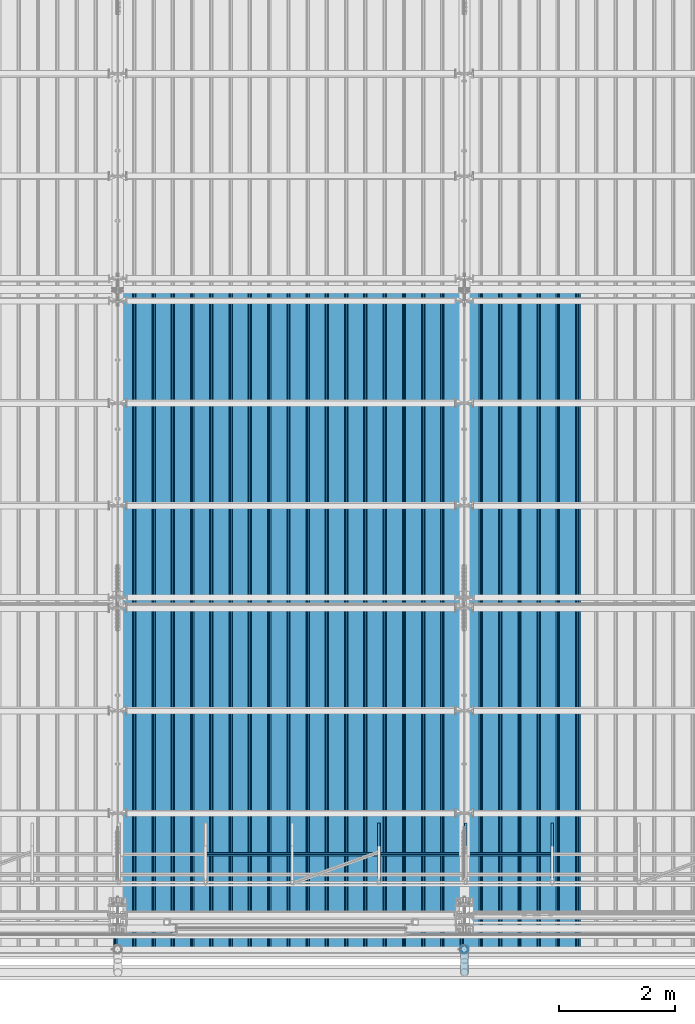
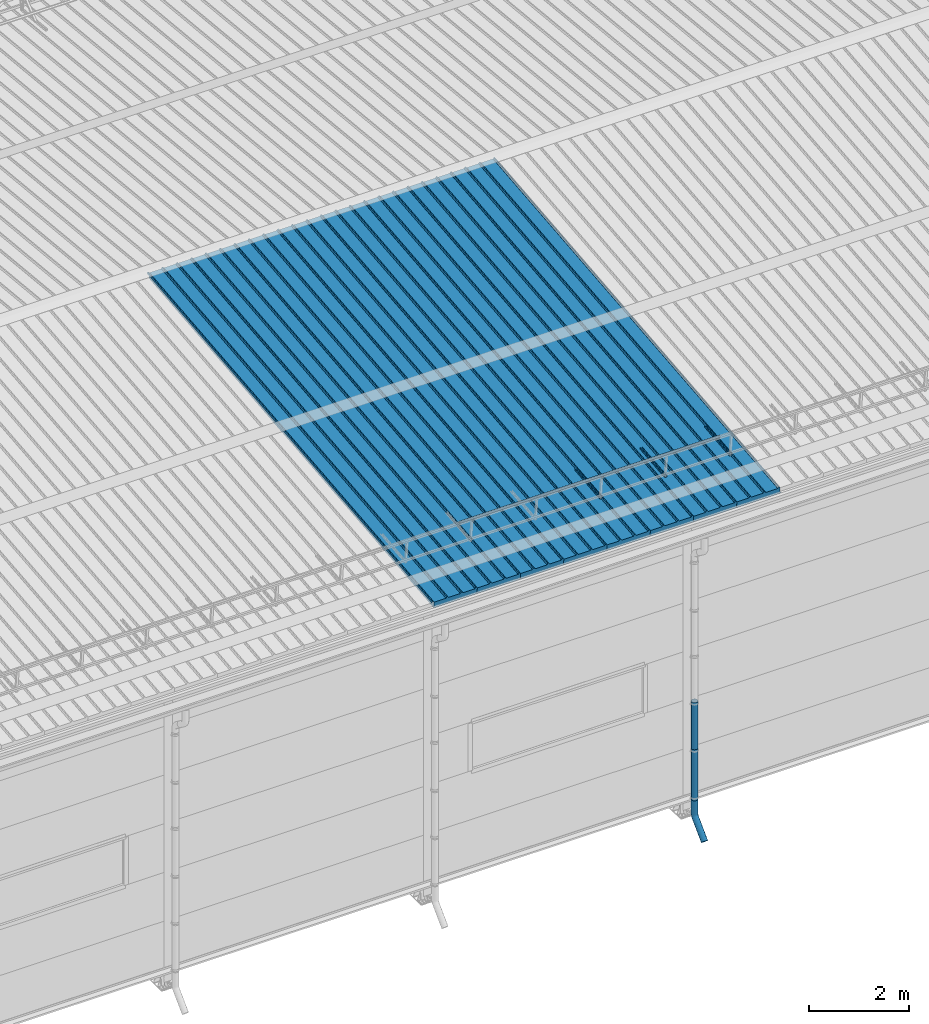
# One storey, part 43 of 709: 15 beams, 15 elements without a shape of their own.
"""IFC4 building model written with IfcOpenShell, lengths in millimetres."""

from ifc_helpers import new_model, entity, si_unit, direction, frame, origin_with_axes, place, context, subcontext, project, spatial, line, indexed_curve, outline, extrude, material, element, aggregate, save


model = new_model("IFC4")

# Units and contexts
model_context = context("Model", 3, precision=0.2, world=origin_with_axes(), true_north=direction((0.0, 1.0)))
body_context = subcontext(model_context, "Body", "Model", "MODEL_VIEW")
ifc_project = project(units=[si_unit("LENGTHUNIT", "METRE", prefix="MILLI"), si_unit("AREAUNIT", "SQUARE_METRE"), si_unit("VOLUMEUNIT", "CUBIC_METRE"), si_unit("MASSUNIT", "GRAM", prefix="KILO"), si_unit("TIMEUNIT", "SECOND"), si_unit("PLANEANGLEUNIT", "RADIAN"), si_unit("SOLIDANGLEUNIT", "STERADIAN"), si_unit("THERMODYNAMICTEMPERATUREUNIT", "DEGREE_CELSIUS"), si_unit("LUMINOUSINTENSITYUNIT", "LUMEN")], contexts=[model_context])

# Site, building, storey
site_placement = place(None, origin_with_axes())
site = spatial("IfcSite", under=ifc_project, at=site_placement, CompositionType="ELEMENT")
building_placement = place(site_placement, origin_with_axes())
building = spatial("IfcBuilding", under=site, at=building_placement, Name="Undefined", CompositionType="ELEMENT")
storey_placement = place(building_placement, origin_with_axes())
storey = spatial("IfcBuildingStorey", under=building, at=storey_placement, Name="Undefined", CompositionType="ELEMENT", Elevation=0.0)

# Assembly, beam
assembly_1_placement = place(storey_placement, frame((23452.44, -410.89541, 7279.78979), z_axis=(1.0, 0.0, 0.0), x_axis=(0.0, 0.9950371902, 0.099503719)))
assembly_1 = element("IfcElementAssembly", 1, at=assembly_1_placement, inside=storey)
ifc_material_1 = material(Name="Insulation", Category="Insulation")
beam_1_placement = place(assembly_1_placement, origin_with_axes())
beam_1 = element("IfcBeam", 2, at=beam_1_placement, material=ifc_material_1, ObjectType="P-99", context=body_context, shape_type="SolidModel", body=[
    extrude(outline(indexed_curve([(-509.8453, 89.5), (-490.1547, 89.5), (-471.67949, 57.5), (-471.67949, -88.5), (-436.67949, -88.5), (-436.67949, -91.5), (562.55841, -91.5), (562.55841, -89.5), (527.55841, -89.5), (527.55841, 57.5), (510.2379, 88.5), (489.7621, 88.5), (472.44159, 58.5), (196.71923, 58.5), (177.66667, 91.5), (155.66667, 91.5), (136.61411, 58.5), (-136.61411, 58.5), (-155.66667, 91.5), (-177.66667, 91.5), (-196.71923, 58.5), (-469.94744, 58.5), (-489.0, 91.5), (-511.0, 91.5), (-527.16581, 63.5), (-525.43376, 62.5)], segments=[line(1, 2, 3, 4, 5, 6, 7, 8, 9, 10, 11, 12, 13, 14, 15, 16, 17, 18, 19, 20, 21, 22, 23, 24, 25, 26, 1)])), frame((0.0, 0.0, 0.0), z_axis=(-1.0, 0.0, 0.0), x_axis=(0.0, 0.0, 1.0)), (0.0, 0.0, -1.0), 11459.0),
])
aggregate(assembly_1, [beam_1])

assembly_2_placement = place(storey_placement, frame((22452.44, -410.89541, 7279.78979), z_axis=(1.0, 0.0, 0.0), x_axis=(0.0, 0.9950371902, 0.099503719)))
assembly_2 = element("IfcElementAssembly", 3, at=assembly_2_placement, inside=storey)
beam_2_placement = place(assembly_2_placement, origin_with_axes())
beam_2 = element("IfcBeam", 4, at=beam_2_placement, material=ifc_material_1, ObjectType="P-99", context=body_context, shape_type="SolidModel", body=[
    extrude(outline(indexed_curve([(-509.8453, 89.5), (-490.1547, 89.5), (-471.67949, 57.5), (-471.67949, -88.5), (-436.67949, -88.5), (-436.67949, -91.5), (562.55841, -91.5), (562.55841, -89.5), (527.55841, -89.5), (527.55841, 57.5), (510.2379, 88.5), (489.7621, 88.5), (472.44159, 58.5), (196.71923, 58.5), (177.66667, 91.5), (155.66667, 91.5), (136.61411, 58.5), (-136.61411, 58.5), (-155.66667, 91.5), (-177.66667, 91.5), (-196.71923, 58.5), (-469.94744, 58.5), (-489.0, 91.5), (-511.0, 91.5), (-527.16581, 63.5), (-525.43376, 62.5)], segments=[line(1, 2, 3, 4, 5, 6, 7, 8, 9, 10, 11, 12, 13, 14, 15, 16, 17, 18, 19, 20, 21, 22, 23, 24, 25, 26, 1)])), frame((0.0, 0.0, 0.0), z_axis=(-1.0, 0.0, 0.0), x_axis=(0.0, 0.0, 1.0)), (0.0, 0.0, -1.0), 11459.0),
])
aggregate(assembly_2, [beam_2])

assembly_3_placement = place(storey_placement, frame((21452.44, -410.89541, 7279.78979), z_axis=(1.0, 0.0, 0.0), x_axis=(0.0, 0.9950371902, 0.099503719)))
assembly_3 = element("IfcElementAssembly", 5, at=assembly_3_placement, inside=storey)
beam_3_placement = place(assembly_3_placement, origin_with_axes())
beam_3 = element("IfcBeam", 6, at=beam_3_placement, material=ifc_material_1, ObjectType="P-99", context=body_context, shape_type="SolidModel", body=[
    extrude(outline(indexed_curve([(-509.8453, 89.5), (-490.1547, 89.5), (-471.67949, 57.5), (-471.67949, -88.5), (-436.67949, -88.5), (-436.67949, -91.5), (562.55841, -91.5), (562.55841, -89.5), (527.55841, -89.5), (527.55841, 57.5), (510.2379, 88.5), (489.7621, 88.5), (472.44159, 58.5), (196.71923, 58.5), (177.66667, 91.5), (155.66667, 91.5), (136.61411, 58.5), (-136.61411, 58.5), (-155.66667, 91.5), (-177.66667, 91.5), (-196.71923, 58.5), (-469.94744, 58.5), (-489.0, 91.5), (-511.0, 91.5), (-527.16581, 63.5), (-525.43376, 62.5)], segments=[line(1, 2, 3, 4, 5, 6, 7, 8, 9, 10, 11, 12, 13, 14, 15, 16, 17, 18, 19, 20, 21, 22, 23, 24, 25, 26, 1)])), frame((0.0, 0.0, 0.0), z_axis=(-1.0, 0.0, 0.0), x_axis=(0.0, 0.0, 1.0)), (0.0, 0.0, -1.0), 11459.0),
])
aggregate(assembly_3, [beam_3])

assembly_4_placement = place(storey_placement, frame((20452.44, -410.89541, 7279.78979), z_axis=(1.0, 0.0, 0.0), x_axis=(0.0, 0.9950371902, 0.099503719)))
assembly_4 = element("IfcElementAssembly", 7, at=assembly_4_placement, inside=storey)
beam_4_placement = place(assembly_4_placement, origin_with_axes())
beam_4 = element("IfcBeam", 8, at=beam_4_placement, material=ifc_material_1, ObjectType="P-99", context=body_context, shape_type="SolidModel", body=[
    extrude(outline(indexed_curve([(-509.8453, 89.5), (-490.1547, 89.5), (-471.67949, 57.5), (-471.67949, -88.5), (-436.67949, -88.5), (-436.67949, -91.5), (562.55841, -91.5), (562.55841, -89.5), (527.55841, -89.5), (527.55841, 57.5), (510.2379, 88.5), (489.7621, 88.5), (472.44159, 58.5), (196.71923, 58.5), (177.66667, 91.5), (155.66667, 91.5), (136.61411, 58.5), (-136.61411, 58.5), (-155.66667, 91.5), (-177.66667, 91.5), (-196.71923, 58.5), (-469.94744, 58.5), (-489.0, 91.5), (-511.0, 91.5), (-527.16581, 63.5), (-525.43376, 62.5)], segments=[line(1, 2, 3, 4, 5, 6, 7, 8, 9, 10, 11, 12, 13, 14, 15, 16, 17, 18, 19, 20, 21, 22, 23, 24, 25, 26, 1)])), frame((0.0, 0.0, 0.0), z_axis=(-1.0, 0.0, 0.0), x_axis=(0.0, 0.0, 1.0)), (0.0, 0.0, -1.0), 11459.0),
])
aggregate(assembly_4, [beam_4])

assembly_5_placement = place(storey_placement, frame((19452.44, -410.89541, 7279.78979), z_axis=(1.0, 0.0, 0.0), x_axis=(0.0, 0.9950371902, 0.099503719)))
assembly_5 = element("IfcElementAssembly", 9, at=assembly_5_placement, inside=storey)
beam_5_placement = place(assembly_5_placement, origin_with_axes())
beam_5 = element("IfcBeam", 10, at=beam_5_placement, material=ifc_material_1, ObjectType="P-99", context=body_context, shape_type="SolidModel", body=[
    extrude(outline(indexed_curve([(-509.8453, 89.5), (-490.1547, 89.5), (-471.67949, 57.5), (-471.67949, -88.5), (-436.67949, -88.5), (-436.67949, -91.5), (562.55841, -91.5), (562.55841, -89.5), (527.55841, -89.5), (527.55841, 57.5), (510.2379, 88.5), (489.7621, 88.5), (472.44159, 58.5), (196.71923, 58.5), (177.66667, 91.5), (155.66667, 91.5), (136.61411, 58.5), (-136.61411, 58.5), (-155.66667, 91.5), (-177.66667, 91.5), (-196.71923, 58.5), (-469.94744, 58.5), (-489.0, 91.5), (-511.0, 91.5), (-527.16581, 63.5), (-525.43376, 62.5)], segments=[line(1, 2, 3, 4, 5, 6, 7, 8, 9, 10, 11, 12, 13, 14, 15, 16, 17, 18, 19, 20, 21, 22, 23, 24, 25, 26, 1)])), frame((0.0, 0.0, 0.0), z_axis=(-1.0, 0.0, 0.0), x_axis=(0.0, 0.0, 1.0)), (0.0, 0.0, -1.0), 11459.0),
])
aggregate(assembly_5, [beam_5])

assembly_6_placement = place(storey_placement, frame((18452.44, -410.89541, 7279.78979), z_axis=(1.0, 0.0, 0.0), x_axis=(0.0, 0.9950371902, 0.099503719)))
assembly_6 = element("IfcElementAssembly", 11, at=assembly_6_placement, inside=storey)
beam_6_placement = place(assembly_6_placement, origin_with_axes())
beam_6 = element("IfcBeam", 12, at=beam_6_placement, material=ifc_material_1, ObjectType="P-99", context=body_context, shape_type="SolidModel", body=[
    extrude(outline(indexed_curve([(-509.8453, 89.5), (-490.1547, 89.5), (-471.67949, 57.5), (-471.67949, -88.5), (-436.67949, -88.5), (-436.67949, -91.5), (562.55841, -91.5), (562.55841, -89.5), (527.55841, -89.5), (527.55841, 57.5), (510.2379, 88.5), (489.7621, 88.5), (472.44159, 58.5), (196.71923, 58.5), (177.66667, 91.5), (155.66667, 91.5), (136.61411, 58.5), (-136.61411, 58.5), (-155.66667, 91.5), (-177.66667, 91.5), (-196.71923, 58.5), (-469.94744, 58.5), (-489.0, 91.5), (-511.0, 91.5), (-527.16581, 63.5), (-525.43376, 62.5)], segments=[line(1, 2, 3, 4, 5, 6, 7, 8, 9, 10, 11, 12, 13, 14, 15, 16, 17, 18, 19, 20, 21, 22, 23, 24, 25, 26, 1)])), frame((0.0, 0.0, 0.0), z_axis=(-1.0, 0.0, 0.0), x_axis=(0.0, 0.0, 1.0)), (0.0, 0.0, -1.0), 11459.0),
])
aggregate(assembly_6, [beam_6])

assembly_7_placement = place(storey_placement, frame((17452.44, -410.89541, 7279.78979), z_axis=(1.0, 0.0, 0.0), x_axis=(0.0, 0.9950371902, 0.099503719)))
assembly_7 = element("IfcElementAssembly", 13, at=assembly_7_placement, inside=storey)
beam_7_placement = place(assembly_7_placement, origin_with_axes())
beam_7 = element("IfcBeam", 14, at=beam_7_placement, material=ifc_material_1, ObjectType="P-99", context=body_context, shape_type="SolidModel", body=[
    extrude(outline(indexed_curve([(-509.8453, 89.5), (-490.1547, 89.5), (-471.67949, 57.5), (-471.67949, -88.5), (-436.67949, -88.5), (-436.67949, -91.5), (562.55841, -91.5), (562.55841, -89.5), (527.55841, -89.5), (527.55841, 57.5), (510.2379, 88.5), (489.7621, 88.5), (472.44159, 58.5), (196.71923, 58.5), (177.66667, 91.5), (155.66667, 91.5), (136.61411, 58.5), (-136.61411, 58.5), (-155.66667, 91.5), (-177.66667, 91.5), (-196.71923, 58.5), (-469.94744, 58.5), (-489.0, 91.5), (-511.0, 91.5), (-527.16581, 63.5), (-525.43376, 62.5)], segments=[line(1, 2, 3, 4, 5, 6, 7, 8, 9, 10, 11, 12, 13, 14, 15, 16, 17, 18, 19, 20, 21, 22, 23, 24, 25, 26, 1)])), frame((0.0, 0.0, 0.0), z_axis=(-1.0, 0.0, 0.0), x_axis=(0.0, 0.0, 1.0)), (0.0, 0.0, -1.0), 11459.0),
])
aggregate(assembly_7, [beam_7])

assembly_8_placement = place(storey_placement, frame((16452.44, -410.89541, 7279.78979), z_axis=(1.0, 0.0, 0.0), x_axis=(0.0, 0.9950371902, 0.099503719)))
assembly_8 = element("IfcElementAssembly", 15, at=assembly_8_placement, inside=storey)
beam_8_placement = place(assembly_8_placement, origin_with_axes())
beam_8 = element("IfcBeam", 16, at=beam_8_placement, material=ifc_material_1, ObjectType="P-99", context=body_context, shape_type="SolidModel", body=[
    extrude(outline(indexed_curve([(-509.8453, 89.5), (-490.1547, 89.5), (-471.67949, 57.5), (-471.67949, -88.5), (-436.67949, -88.5), (-436.67949, -91.5), (562.55841, -91.5), (562.55841, -89.5), (527.55841, -89.5), (527.55841, 57.5), (510.2379, 88.5), (489.7621, 88.5), (472.44159, 58.5), (196.71923, 58.5), (177.66667, 91.5), (155.66667, 91.5), (136.61411, 58.5), (-136.61411, 58.5), (-155.66667, 91.5), (-177.66667, 91.5), (-196.71923, 58.5), (-469.94744, 58.5), (-489.0, 91.5), (-511.0, 91.5), (-527.16581, 63.5), (-525.43376, 62.5)], segments=[line(1, 2, 3, 4, 5, 6, 7, 8, 9, 10, 11, 12, 13, 14, 15, 16, 17, 18, 19, 20, 21, 22, 23, 24, 25, 26, 1)])), frame((0.0, 0.0, 0.0), z_axis=(-1.0, 0.0, 0.0), x_axis=(0.0, 0.0, 1.0)), (0.0, 0.0, -1.0), 11459.0),
])
aggregate(assembly_8, [beam_8])

assembly_9_placement = place(storey_placement, frame((20520.0, 768.92298, 7577.16191), z_axis=(0.0, -0.099503719, 0.9950371902), x_axis=(0.0, 0.9950371902, 0.099503719)))
assembly_9 = element("IfcElementAssembly", 17, at=assembly_9_placement, inside=storey)
ifc_material_2 = material(Name="Steel_Undefined", Category="STEEL")
beam_9_placement = place(assembly_9_placement, origin_with_axes())
beam_9 = element("IfcBeam", 18, at=beam_9_placement, material=ifc_material_2, ObjectType="601", context=body_context, shape_type="SolidModel", body=[
    extrude(outline(indexed_curve([(-20.0, -25.0), (20.0, -25.0), (20.0, -22.5), (-17.5, -22.5), (-17.5, 22.5), (20.0, 22.5), (20.0, 25.0), (-20.0, 25.0)], segments=[line(1, 2, 3, 4, 5, 6, 7, 8, 1)])), frame((0.0, 0.0, 0.0), z_axis=(-1.0, 0.0, 0.0), x_axis=(0.0, 0.0, 1.0)), (0.0, 0.0, -1.0), 1000.0),
])
aggregate(assembly_9, [beam_9])

assembly_10_placement = place(storey_placement, frame((22020.0, 768.92298, 7577.16191), z_axis=(0.0, -0.099503719, 0.9950371902), x_axis=(0.0, 0.9950371902, 0.099503719)))
assembly_10 = element("IfcElementAssembly", 19, at=assembly_10_placement, inside=storey)
beam_10_placement = place(assembly_10_placement, origin_with_axes())
beam_10 = element("IfcBeam", 20, at=beam_10_placement, material=ifc_material_2, ObjectType="601", context=body_context, shape_type="SolidModel", body=[
    extrude(outline(indexed_curve([(-20.0, -25.0), (20.0, -25.0), (20.0, -22.5), (-17.5, -22.5), (-17.5, 22.5), (20.0, 22.5), (20.0, 25.0), (-20.0, 25.0)], segments=[line(1, 2, 3, 4, 5, 6, 7, 8, 1)])), frame((0.0, 0.0, 0.0), z_axis=(-1.0, 0.0, 0.0), x_axis=(0.0, 0.0, 1.0)), (0.0, 0.0, -1.0), 1000.0),
])
aggregate(assembly_10, [beam_10])

assembly_11_placement = place(storey_placement, frame((17520.0, 1225.80867, 7759.0901), z_axis=(0.0, 0.6332377902, 0.7739572992), x_axis=(1.0, 0.0, 0.0)))
assembly_11 = element("IfcElementAssembly", 21, at=assembly_11_placement, inside=storey)
beam_11_placement = place(assembly_11_placement, origin_with_axes())
beam_11 = element("IfcBeam", 22, at=beam_11_placement, material=ifc_material_2, ObjectType="606", context=body_context, shape_type="SolidModel", body=[
    extrude(outline(indexed_curve([(-20.0, -25.0), (20.0, -25.0), (20.0, -22.5), (-17.5, -22.5), (-17.5, 22.5), (20.0, 22.5), (20.0, 25.0), (-20.0, 25.0)], segments=[line(1, 2, 3, 4, 5, 6, 7, 8, 1)])), frame((0.0, 0.0, 0.0), z_axis=(-1.0, 0.0, 0.0), x_axis=(0.0, 0.0, 1.0)), (0.0, 0.0, -1.0), 6000.0),
])
aggregate(assembly_11, [beam_11])

assembly_12_placement = place(storey_placement, frame((23520.0, 768.92298, 7577.16191), z_axis=(0.0, -0.099503719, 0.9950371902), x_axis=(0.0, 0.9950371902, 0.099503719)))
assembly_12 = element("IfcElementAssembly", 23, at=assembly_12_placement, inside=storey)
beam_12_placement = place(assembly_12_placement, origin_with_axes())
beam_12 = element("IfcBeam", 24, at=beam_12_placement, material=ifc_material_2, ObjectType="601", context=body_context, shape_type="SolidModel", body=[
    extrude(outline(indexed_curve([(-20.0, -25.0), (20.0, -25.0), (20.0, -22.5), (-17.5, -22.5), (-17.5, 22.5), (20.0, 22.5), (20.0, 25.0), (-20.0, 25.0)], segments=[line(1, 2, 3, 4, 5, 6, 7, 8, 1)])), frame((0.0, 0.0, 0.0), z_axis=(-1.0, 0.0, 0.0), x_axis=(0.0, 0.0, 1.0)), (0.0, 0.0, -1.0), 1000.0),
])
aggregate(assembly_12, [beam_12])

assembly_13_placement = place(storey_placement, frame((22000.0, -420.0, 2826.92297), z_axis=(0.0, 1.0, 0.0), x_axis=(0.0, 0.0, -1.0)))
assembly_13 = element("IfcElementAssembly", 25, at=assembly_13_placement, inside=storey)
beam_13_placement = place(assembly_13_placement, origin_with_axes())
beam_13 = element("IfcBeam", 26, at=beam_13_placement, material=ifc_material_2, ObjectType="614", context=body_context, shape_type="SolidModel", body=[
    extrude(outline(indexed_curve([(70.0, 0.0), (69.61653, 7.31699), (68.47033, 14.55382), (66.57396, 21.63119), (63.94818, 28.47157), (60.62178, 35.0), (56.63119, 41.14497), (52.02014, 46.83914), (46.83914, 52.02014), (41.14497, 56.63119), (35.0, 60.62178), (28.47157, 63.94818), (21.63119, 66.57396), (14.55382, 68.47033), (7.31699, 69.61653), (0.0, 70.0), (-7.31699, 69.61653), (-14.55382, 68.47033), (-21.63119, 66.57396), (-28.47157, 63.94818), (-35.0, 60.62178), (-41.14497, 56.63119), (-46.83914, 52.02014), (-52.02014, 46.83914), (-56.63119, 41.14497), (-60.62178, 35.0), (-63.94818, 28.47157), (-66.57396, 21.63119), (-68.47033, 14.55382), (-69.61653, 7.31699), (-70.0, 0.0), (-69.61653, -7.31699), (-68.47033, -14.55382), (-66.57396, -21.63119), (-63.94818, -28.47157), (-60.62178, -35.0), (-56.63119, -41.14497), (-52.02014, -46.83914), (-46.83914, -52.02014), (-41.14497, -56.63119), (-35.0, -60.62178), (-28.47157, -63.94818), (-21.63119, -66.57396), (-14.55382, -68.47033), (-7.31699, -69.61653), (0.0, -70.0), (7.31699, -69.61653), (14.55382, -68.47033), (21.63119, -66.57396), (28.47157, -63.94818), (35.0, -60.62178), (41.14497, -56.63119), (46.83914, -52.02014), (52.02014, -46.83914), (56.63119, -41.14497), (60.62178, -35.0), (63.94818, -28.47157), (66.57396, -21.63119), (68.47033, -14.55382), (69.61653, -7.31699)], segments=[line(1, 2, 3, 4, 5, 6, 7, 8, 9, 10, 11, 12, 13, 14, 15, 16, 17, 18, 19, 20, 21, 22, 23, 24, 25, 26, 27, 28, 29, 30, 31, 32, 33, 34, 35, 36, 37, 38, 39, 40, 41, 42, 43, 44, 45, 46, 47, 48, 49, 50, 51, 52, 53, 54, 55, 56, 57, 58, 59, 60, 1)]), holes=[indexed_curve([(65.0, 0.0), (64.64392, -6.79435), (63.57959, -13.51426), (61.81867, -20.0861), (59.38045, -26.43788), (56.29165, -32.5), (52.5861, -38.20604), (48.30441, -43.49349), (43.49349, -48.30441), (38.20604, -52.5861), (32.5, -56.29165), (26.43788, -59.38045), (20.0861, -61.81867), (13.51426, -63.57959), (6.79435, -64.64392), (0.0, -65.0), (-6.79435, -64.64392), (-13.51426, -63.57959), (-20.0861, -61.81867), (-26.43788, -59.38045), (-32.5, -56.29165), (-38.20604, -52.5861), (-43.49349, -48.30441), (-48.30441, -43.49349), (-52.5861, -38.20604), (-56.29165, -32.5), (-59.38045, -26.43788), (-61.81867, -20.0861), (-63.57959, -13.51426), (-64.64392, -6.79435), (-65.0, 0.0), (-64.64392, 6.79435), (-63.57959, 13.51426), (-61.81867, 20.0861), (-59.38045, 26.43788), (-56.29165, 32.5), (-52.5861, 38.20604), (-48.30441, 43.49349), (-43.49349, 48.30441), (-38.20604, 52.5861), (-32.5, 56.29165), (-26.43788, 59.38045), (-20.0861, 61.81867), (-13.51426, 63.57959), (-6.79435, 64.64392), (0.0, 65.0), (6.79435, 64.64392), (13.51426, 63.57959), (20.0861, 61.81867), (26.43788, 59.38045), (32.5, 56.29165), (38.20604, 52.5861), (43.49349, 48.30441), (48.30441, 43.49349), (52.5861, 38.20604), (56.29165, 32.5), (59.38045, 26.43788), (61.81867, 20.0861), (63.57959, 13.51426), (64.64392, 6.79435)], segments=[line(1, 2, 3, 4, 5, 6, 7, 8, 9, 10, 11, 12, 13, 14, 15, 16, 17, 18, 19, 20, 21, 22, 23, 24, 25, 26, 27, 28, 29, 30, 31, 32, 33, 34, 35, 36, 37, 38, 39, 40, 41, 42, 43, 44, 45, 46, 47, 48, 49, 50, 51, 52, 53, 54, 55, 56, 57, 58, 59, 60, 1)])]), frame((0.0, 0.0, 0.0), z_axis=(-1.0, 0.0, 0.0), x_axis=(0.0, 0.0, 1.0)), (0.0, 0.0, -1.0), 1250.0),
])
aggregate(assembly_13, [beam_13])

assembly_14_placement = place(storey_placement, frame((22000.0, -420.0, 1676.92297), z_axis=(0.0, 1.0, 0.0), x_axis=(0.0, 0.0, -1.0)))
assembly_14 = element("IfcElementAssembly", 27, at=assembly_14_placement, inside=storey)
beam_14_placement = place(assembly_14_placement, origin_with_axes())
beam_14 = element("IfcBeam", 28, at=beam_14_placement, material=ifc_material_2, ObjectType="614", context=body_context, shape_type="SolidModel", body=[
    extrude(outline(indexed_curve([(70.0, 0.0), (69.61653, 7.31699), (68.47033, 14.55382), (66.57396, 21.63119), (63.94818, 28.47157), (60.62178, 35.0), (56.63119, 41.14497), (52.02014, 46.83914), (46.83914, 52.02014), (41.14497, 56.63119), (35.0, 60.62178), (28.47157, 63.94818), (21.63119, 66.57396), (14.55382, 68.47033), (7.31699, 69.61653), (0.0, 70.0), (-7.31699, 69.61653), (-14.55382, 68.47033), (-21.63119, 66.57396), (-28.47157, 63.94818), (-35.0, 60.62178), (-41.14497, 56.63119), (-46.83914, 52.02014), (-52.02014, 46.83914), (-56.63119, 41.14497), (-60.62178, 35.0), (-63.94818, 28.47157), (-66.57396, 21.63119), (-68.47033, 14.55382), (-69.61653, 7.31699), (-70.0, 0.0), (-69.61653, -7.31699), (-68.47033, -14.55382), (-66.57396, -21.63119), (-63.94818, -28.47157), (-60.62178, -35.0), (-56.63119, -41.14497), (-52.02014, -46.83914), (-46.83914, -52.02014), (-41.14497, -56.63119), (-35.0, -60.62178), (-28.47157, -63.94818), (-21.63119, -66.57396), (-14.55382, -68.47033), (-7.31699, -69.61653), (0.0, -70.0), (7.31699, -69.61653), (14.55382, -68.47033), (21.63119, -66.57396), (28.47157, -63.94818), (35.0, -60.62178), (41.14497, -56.63119), (46.83914, -52.02014), (52.02014, -46.83914), (56.63119, -41.14497), (60.62178, -35.0), (63.94818, -28.47157), (66.57396, -21.63119), (68.47033, -14.55382), (69.61653, -7.31699)], segments=[line(1, 2, 3, 4, 5, 6, 7, 8, 9, 10, 11, 12, 13, 14, 15, 16, 17, 18, 19, 20, 21, 22, 23, 24, 25, 26, 27, 28, 29, 30, 31, 32, 33, 34, 35, 36, 37, 38, 39, 40, 41, 42, 43, 44, 45, 46, 47, 48, 49, 50, 51, 52, 53, 54, 55, 56, 57, 58, 59, 60, 1)]), holes=[indexed_curve([(65.0, 0.0), (64.64392, -6.79435), (63.57959, -13.51426), (61.81867, -20.0861), (59.38045, -26.43788), (56.29165, -32.5), (52.5861, -38.20604), (48.30441, -43.49349), (43.49349, -48.30441), (38.20604, -52.5861), (32.5, -56.29165), (26.43788, -59.38045), (20.0861, -61.81867), (13.51426, -63.57959), (6.79435, -64.64392), (0.0, -65.0), (-6.79435, -64.64392), (-13.51426, -63.57959), (-20.0861, -61.81867), (-26.43788, -59.38045), (-32.5, -56.29165), (-38.20604, -52.5861), (-43.49349, -48.30441), (-48.30441, -43.49349), (-52.5861, -38.20604), (-56.29165, -32.5), (-59.38045, -26.43788), (-61.81867, -20.0861), (-63.57959, -13.51426), (-64.64392, -6.79435), (-65.0, 0.0), (-64.64392, 6.79435), (-63.57959, 13.51426), (-61.81867, 20.0861), (-59.38045, 26.43788), (-56.29165, 32.5), (-52.5861, 38.20604), (-48.30441, 43.49349), (-43.49349, 48.30441), (-38.20604, 52.5861), (-32.5, 56.29165), (-26.43788, 59.38045), (-20.0861, 61.81867), (-13.51426, 63.57959), (-6.79435, 64.64392), (0.0, 65.0), (6.79435, 64.64392), (13.51426, 63.57959), (20.0861, 61.81867), (26.43788, 59.38045), (32.5, 56.29165), (38.20604, 52.5861), (43.49349, 48.30441), (48.30441, 43.49349), (52.5861, 38.20604), (56.29165, 32.5), (59.38045, 26.43788), (61.81867, 20.0861), (63.57959, 13.51426), (64.64392, 6.79435)], segments=[line(1, 2, 3, 4, 5, 6, 7, 8, 9, 10, 11, 12, 13, 14, 15, 16, 17, 18, 19, 20, 21, 22, 23, 24, 25, 26, 27, 28, 29, 30, 31, 32, 33, 34, 35, 36, 37, 38, 39, 40, 41, 42, 43, 44, 45, 46, 47, 48, 49, 50, 51, 52, 53, 54, 55, 56, 57, 58, 59, 60, 1)])]), frame((0.0, 0.0, 0.0), z_axis=(-1.0, 0.0, 0.0), x_axis=(0.0, 0.0, 1.0)), (0.0, 0.0, -1.0), 1250.0),
])
aggregate(assembly_14, [beam_14])

assembly_15_placement = place(storey_placement, frame((22000.0, -420.0, 526.92297), z_axis=(-1.0, 0.0, 0.0), x_axis=(0.0, 0.0, -1.0)))
assembly_15 = element("IfcElementAssembly", 29, at=assembly_15_placement, inside=storey)
beam_15_placement = place(assembly_15_placement, origin_with_axes())
beam_15 = element("IfcBeam", 30, at=beam_15_placement, material=ifc_material_2, ObjectType="617", context=body_context, shape_type="SolidModel", body=[
    entity("IfcSweptDiskSolid", entity("IfcIndexedPolyCurve", entity("IfcCartesianPointList3D", [[0.0, 0.0, 0.0], [448.2233, 0.0, 0.0], [496.05873, 9.51506, 0.0], [536.61165, 36.61165, 0.0], [900.0, 400.0, 0.0]]), [entity("IfcLineIndex", [1, 2]), entity("IfcArcIndex", [2, 3, 4]), entity("IfcLineIndex", [4, 5])]), 70.0, 65.0),
])
aggregate(assembly_15, [beam_15])

save(model, "model.ifc")
